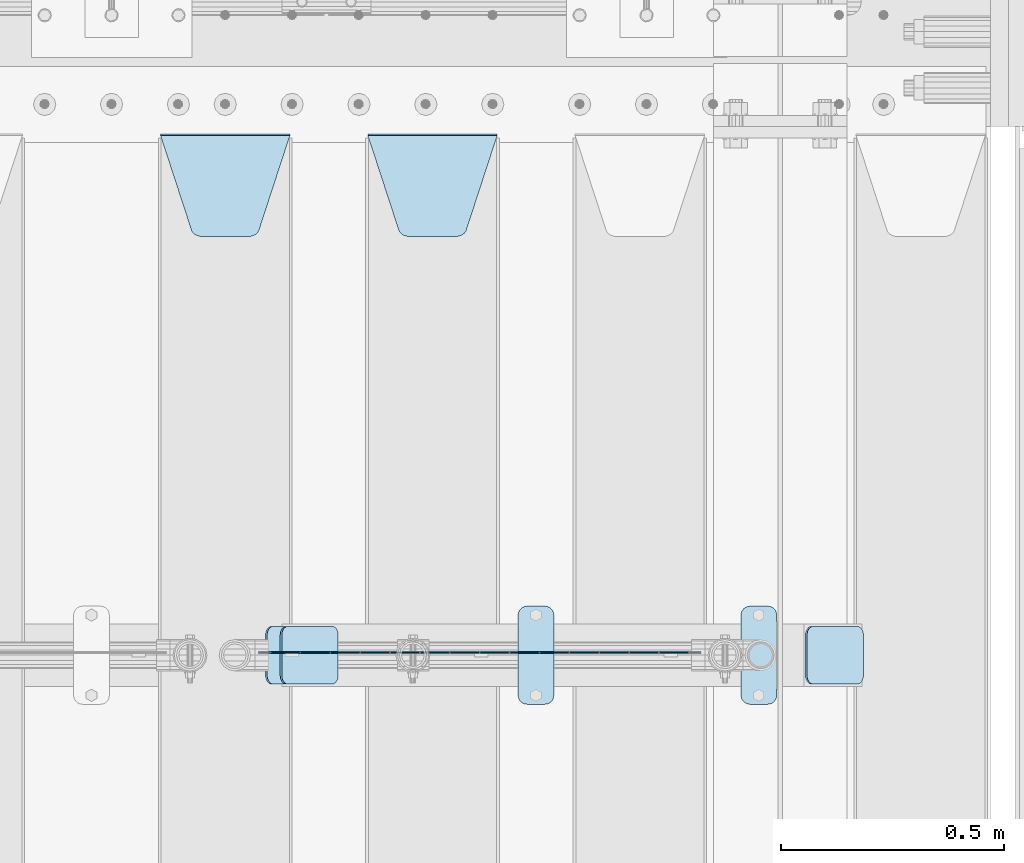
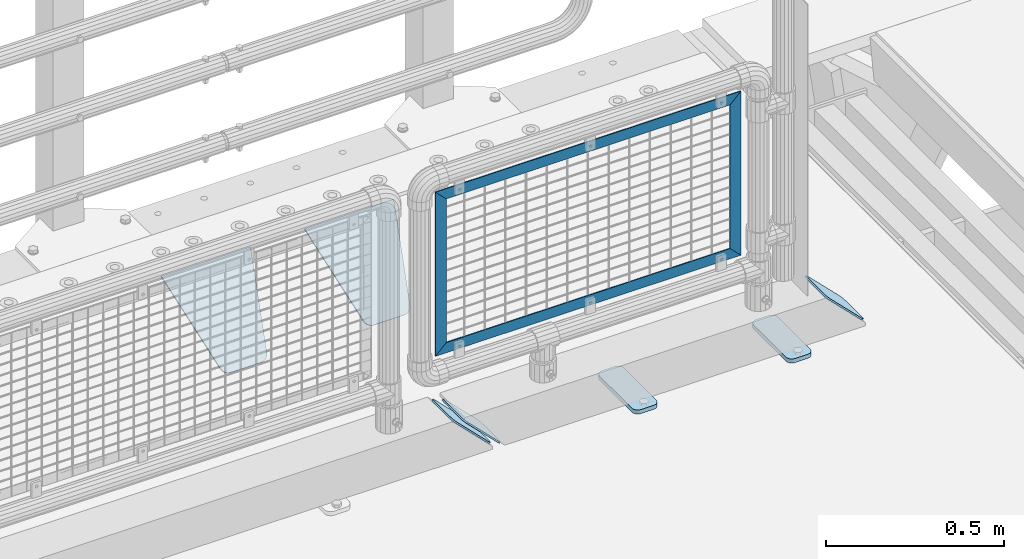
# One storey, part 230 of 247: 11 plates.
"""IFC2X3 building model written with IfcOpenShell, lengths in millimetres."""

from ifc_helpers import new_model, si_unit, frame, origin_with_axes, place, context, subcontext, project, spatial, faceted_brep, material, type_object, element, save


model = new_model("IFC2X3")

# Units and contexts
model_context = context("Model", 3, precision=1e-05, world=origin_with_axes())
body_context = subcontext(model_context, "Body", "Model", "MODEL_VIEW")
ifc_project = project(units=[si_unit("LENGTHUNIT", "METRE", prefix="MILLI"), si_unit("AREAUNIT", "SQUARE_METRE"), si_unit("VOLUMEUNIT", "CUBIC_METRE"), si_unit("MASSUNIT", "GRAM", prefix="KILO"), si_unit("TIMEUNIT", "SECOND"), si_unit("PLANEANGLEUNIT", "RADIAN"), si_unit("SOLIDANGLEUNIT", "STERADIAN"), si_unit("THERMODYNAMICTEMPERATUREUNIT", "DEGREE_CELSIUS"), si_unit("LUMINOUSINTENSITYUNIT", "LUMEN")], contexts=[model_context])

# Site, building, storey
site_placement = place(None, origin_with_axes())
site = spatial("IfcSite", under=ifc_project, at=site_placement, CompositionType="ELEMENT")
building_placement = place(site_placement, origin_with_axes())
building = spatial("IfcBuilding", under=site, at=building_placement, Name="Standard", CompositionType="ELEMENT")
storey_placement = place(building_placement, origin_with_axes())
storey = spatial("IfcBuildingStorey", under=building, at=storey_placement, Name="Undefined", CompositionType="ELEMENT", Elevation=0.0)

# Plates
ifc_material_1 = material(Name="STEEL/S355J2")
plate_type_1 = type_object("IfcPlateType", PredefinedType="NOTDEFINED")
plate_1_placement = place(storey_placement, frame((16257.0, 7774.5, 21.0199999999977), z_axis=(1.0, 0.0, 0.0), x_axis=(0.0, -0.999999999999548, -9.5100000000016e-07)))
element("IfcPlate", 1, at=plate_1_placement, inside=storey, type_object=plate_type_1, material=ifc_material_1, context=body_context, shape_type="Brep", body=[
    faceted_brep([(0.0, -7.0, 20.0), (0.0, -7.0, 60.0), (0.0, 7.0, 60.0), (0.0, 7.0, 20.0), (0.384294391935327, -7.0, 63.9018064403226), (0.384294391935327, 7.0, 63.9018064403226), (1.52240934977453, -7.0, 67.6536686473009), (1.52240934977453, 7.0, 67.6536686473009), (3.37060775394912, -7.0, 71.1114046603925), (3.37060775394912, 7.0, 71.1114046603925), (5.85786437626939, -7.0, 74.1421356237315), (5.85786437626939, 7.0, 74.1421356237315), (8.8885953396084, -7.0, 76.6293922460518), (8.8885953396084, 7.0, 76.6293922460518), (12.3463313526981, -7.0, 78.4775906502255), (12.3463313526981, 7.0, 78.4775906502255), (16.0981935596774, -7.0, 79.6157056080647), (16.0981935596774, 7.0, 79.6157056080647), (20.0, -7.0, 80.0), (20.0, 7.0, 80.0), (200.0, -7.0, 80.0), (200.0, 7.0, 80.0), (203.901806440323, -7.0, 79.6157056080647), (203.901806440323, 7.0, 79.6157056080647), (207.653668647302, -7.0, 78.4775906502255), (207.653668647302, 7.0, 78.4775906502255), (211.111404660392, -7.0, 76.6293922460518), (211.111404660392, 7.0, 76.6293922460518), (214.142135623731, -7.0, 74.1421356237315), (214.142135623731, 7.0, 74.1421356237315), (216.629392246051, -7.0, 71.1114046603925), (216.629392246051, 7.0, 71.1114046603925), (218.477590650225, -7.0, 67.6536686473009), (218.477590650225, 7.0, 67.6536686473009), (219.615705608065, -7.0, 63.9018064403226), (219.615705608065, 7.0, 63.9018064403226), (220.0, -7.0, 60.0), (220.0, 7.0, 60.0), (220.0, -7.0, 20.0), (220.0, 7.0, 20.0), (219.615705608065, -7.0, 16.0981935596774), (219.615705608065, 7.0, 16.0981935596774), (218.477590650225, -7.0, 12.3463313526991), (218.477590650225, 7.0, 12.3463313526991), (216.629392246051, -7.0, 8.88859533960749), (216.629392246051, 7.0, 8.88859533960749), (214.142135623731, -7.0, 5.85786437626848), (214.142135623731, 7.0, 5.85786437626848), (211.111404660392, -7.0, 3.37060775394821), (211.111404660392, 7.0, 3.37060775394821), (207.653668647302, -7.0, 1.52240934977453), (207.653668647302, 7.0, 1.52240934977453), (203.901806440323, -7.0, 0.384294391935327), (203.901806440323, 7.0, 0.384294391935327), (200.0, -7.0, 0.0), (200.0, 7.0, 0.0), (20.0, -7.0, 0.0), (20.0, 7.0, 0.0), (16.0981935596774, -7.0, 0.384294391935327), (16.0981935596774, 7.0, 0.384294391935327), (12.3463313526981, -7.0, 1.52240934977453), (12.3463313526981, 7.0, 1.52240934977453), (8.8885953396084, -7.0, 3.37060775394821), (8.8885953396084, 7.0, 3.37060775394821), (5.85786437626939, -7.0, 5.85786437626848), (5.85786437626939, 7.0, 5.85786437626848), (3.37060775394912, -7.0, 8.88859533960749), (3.37060775394912, 7.0, 8.88859533960749), (1.52240934977453, -7.0, 12.3463313526991), (1.52240934977453, 7.0, 12.3463313526991), (0.384294391935327, -7.0, 16.0981935596774), (0.384294391935327, 7.0, 16.0981935596774)], [[[0, 1, 2, 3]], [[1, 4, 5, 2]], [[4, 6, 7, 5]], [[6, 8, 9, 7]], [[8, 10, 11, 9]], [[10, 12, 13, 11]], [[12, 14, 15, 13]], [[14, 16, 17, 15]], [[16, 18, 19, 17]], [[18, 20, 21, 19]], [[20, 22, 23, 21]], [[22, 24, 25, 23]], [[24, 26, 27, 25]], [[26, 28, 29, 27]], [[28, 30, 31, 29]], [[30, 32, 33, 31]], [[32, 34, 35, 33]], [[34, 36, 37, 35]], [[36, 38, 39, 37]], [[38, 40, 41, 39]], [[40, 42, 43, 41]], [[42, 44, 45, 43]], [[44, 46, 47, 45]], [[46, 48, 49, 47]], [[48, 50, 51, 49]], [[50, 52, 53, 51]], [[52, 54, 55, 53]], [[54, 56, 57, 55]], [[56, 58, 59, 57]], [[58, 60, 61, 59]], [[60, 62, 63, 61]], [[62, 64, 65, 63]], [[64, 66, 67, 65]], [[66, 68, 69, 67]], [[68, 70, 71, 69]], [[70, 0, 3, 71]], [[5, 7, 9, 11, 13, 15, 17, 19, 21, 23, 25, 27, 29, 31, 33, 35, 37, 39, 41, 43, 45, 47, 49, 51, 53, 55, 57, 59, 61, 63, 65, 67, 69, 71, 3, 2]], [[70, 68, 66, 64, 62, 60, 58, 56, 54, 52, 50, 48, 46, 44, 42, 40, 38, 36, 34, 32, 30, 28, 26, 24, 22, 20, 18, 16, 14, 12, 10, 8, 6, 4, 1, 0]]]),
])
plate_2_placement = place(storey_placement, frame((15757.0, 7774.5, 21.0199999999977), z_axis=(1.0, 0.0, 0.0), x_axis=(0.0, -0.999999999999548, -9.5100000000016e-07)))
element("IfcPlate", 2, at=plate_2_placement, inside=storey, type_object=plate_type_1, material=ifc_material_1, context=body_context, shape_type="Brep", body=[
    faceted_brep([(0.0, -7.0, 20.0), (0.0, -7.0, 60.0), (0.0, 7.0, 60.0), (0.0, 7.0, 20.0), (0.384294391935327, -7.0, 63.9018064403226), (0.384294391935327, 7.0, 63.9018064403226), (1.52240934977453, -7.0, 67.6536686473009), (1.52240934977453, 7.0, 67.6536686473009), (3.37060775394912, -7.0, 71.1114046603925), (3.37060775394912, 7.0, 71.1114046603925), (5.85786437626939, -7.0, 74.1421356237315), (5.85786437626939, 7.0, 74.1421356237315), (8.8885953396084, -7.0, 76.6293922460518), (8.8885953396084, 7.0, 76.6293922460518), (12.3463313526981, -7.0, 78.4775906502255), (12.3463313526981, 7.0, 78.4775906502255), (16.0981935596774, -7.0, 79.6157056080647), (16.0981935596774, 7.0, 79.6157056080647), (20.0, -7.0, 80.0), (20.0, 7.0, 80.0), (200.0, -7.0, 80.0), (200.0, 7.0, 80.0), (203.901806440323, -7.0, 79.6157056080647), (203.901806440323, 7.0, 79.6157056080647), (207.653668647302, -7.0, 78.4775906502255), (207.653668647302, 7.0, 78.4775906502255), (211.111404660392, -7.0, 76.6293922460518), (211.111404660392, 7.0, 76.6293922460518), (214.142135623731, -7.0, 74.1421356237315), (214.142135623731, 7.0, 74.1421356237315), (216.629392246051, -7.0, 71.1114046603925), (216.629392246051, 7.0, 71.1114046603925), (218.477590650225, -7.0, 67.6536686473009), (218.477590650225, 7.0, 67.6536686473009), (219.615705608065, -7.0, 63.9018064403226), (219.615705608065, 7.0, 63.9018064403226), (220.0, -7.0, 60.0), (220.0, 7.0, 60.0), (220.0, -7.0, 20.0), (220.0, 7.0, 20.0), (219.615705608065, -7.0, 16.0981935596774), (219.615705608065, 7.0, 16.0981935596774), (218.477590650225, -7.0, 12.3463313526991), (218.477590650225, 7.0, 12.3463313526991), (216.629392246051, -7.0, 8.88859533960749), (216.629392246051, 7.0, 8.88859533960749), (214.142135623731, -7.0, 5.85786437626848), (214.142135623731, 7.0, 5.85786437626848), (211.111404660392, -7.0, 3.37060775394821), (211.111404660392, 7.0, 3.37060775394821), (207.653668647302, -7.0, 1.52240934977453), (207.653668647302, 7.0, 1.52240934977453), (203.901806440323, -7.0, 0.384294391935327), (203.901806440323, 7.0, 0.384294391935327), (200.0, -7.0, 0.0), (200.0, 7.0, 0.0), (20.0, -7.0, 0.0), (20.0, 7.0, 0.0), (16.0981935596774, -7.0, 0.384294391935327), (16.0981935596774, 7.0, 0.384294391935327), (12.3463313526981, -7.0, 1.52240934977453), (12.3463313526981, 7.0, 1.52240934977453), (8.8885953396084, -7.0, 3.37060775394821), (8.8885953396084, 7.0, 3.37060775394821), (5.85786437626939, -7.0, 5.85786437626848), (5.85786437626939, 7.0, 5.85786437626848), (3.37060775394912, -7.0, 8.88859533960749), (3.37060775394912, 7.0, 8.88859533960749), (1.52240934977453, -7.0, 12.3463313526991), (1.52240934977453, 7.0, 12.3463313526991), (0.384294391935327, -7.0, 16.0981935596774), (0.384294391935327, 7.0, 16.0981935596774)], [[[0, 1, 2, 3]], [[1, 4, 5, 2]], [[4, 6, 7, 5]], [[6, 8, 9, 7]], [[8, 10, 11, 9]], [[10, 12, 13, 11]], [[12, 14, 15, 13]], [[14, 16, 17, 15]], [[16, 18, 19, 17]], [[18, 20, 21, 19]], [[20, 22, 23, 21]], [[22, 24, 25, 23]], [[24, 26, 27, 25]], [[26, 28, 29, 27]], [[28, 30, 31, 29]], [[30, 32, 33, 31]], [[32, 34, 35, 33]], [[34, 36, 37, 35]], [[36, 38, 39, 37]], [[38, 40, 41, 39]], [[40, 42, 43, 41]], [[42, 44, 45, 43]], [[44, 46, 47, 45]], [[46, 48, 49, 47]], [[48, 50, 51, 49]], [[50, 52, 53, 51]], [[52, 54, 55, 53]], [[54, 56, 57, 55]], [[56, 58, 59, 57]], [[58, 60, 61, 59]], [[60, 62, 63, 61]], [[62, 64, 65, 63]], [[64, 66, 67, 65]], [[66, 68, 69, 67]], [[68, 70, 71, 69]], [[70, 0, 3, 71]], [[5, 7, 9, 11, 13, 15, 17, 19, 21, 23, 25, 27, 29, 31, 33, 35, 37, 39, 41, 43, 45, 47, 49, 51, 53, 55, 57, 59, 61, 63, 65, 67, 69, 71, 3, 2]], [[70, 68, 66, 64, 62, 60, 58, 56, 54, 52, 50, 48, 46, 44, 42, 40, 38, 36, 34, 32, 30, 28, 26, 24, 22, 20, 18, 16, 14, 12, 10, 8, 6, 4, 1, 0]]]),
])
ifc_material_2 = material(Name="STEEL/S355N")
plate_type_2 = type_object("IfcPlateType", PredefinedType="NOTDEFINED")
plate_3_placement = place(storey_placement, frame((15420.0, 8831.76776695594, -1.767766952965), z_axis=(0.0, -0.707106781186548, -0.707106781186547), x_axis=(1.0, 0.0, 0.0)))
element("IfcPlate", 3, at=plate_3_placement, inside=storey, type_object=plate_type_2, material=ifc_material_2, context=body_context, shape_type="Brep", body=[
    faceted_brep([(0.0, -2.49999999999909, 0.0), (69.345504679477, -2.5, 300.17173142483), (69.345504679477, 2.50000000000091, 300.171731424831), (0.0, 2.5, -9.09494701772928e-13), (70.9274061199576, -2.5, 304.897442415399), (70.9274061199576, 2.50000000000091, 304.8974424154), (73.3818627772307, -2.49999999999909, 309.234538108527), (73.3818627772307, 2.5, 309.234538108526), (76.6187032999551, -2.5, 313.023683126102), (76.6187032999551, 2.50000000000091, 313.023683126102), (80.5190132704993, -2.49999999999909, 316.125672595371), (80.5190132704993, 2.50000000000091, 316.125672595372), (84.9395038596849, -2.49999999999909, 318.426546230476), (84.9395038596849, 2.5, 318.426546230475), (89.7177759439219, -2.5, 319.841774983274), (89.7177759439219, 2.50000000000091, 319.841774983275), (94.678286292652, -2.5, 320.319366455077), (94.678286292652, 2.50000000000091, 320.319366455077), (195.321713707348, -2.5, 320.319366455077), (195.321713707348, 2.50000000000091, 320.319366455077), (200.282224056078, -2.5, 319.841774983274), (200.282224056078, 2.50000000000091, 319.841774983275), (205.060496140315, -2.5, 318.426546230475), (205.060496140315, 2.5, 318.426546230474), (209.480986729501, -2.49999999999818, 316.12567259537), (209.480986729501, 2.50000000000091, 316.12567259537), (213.381296700045, -2.5, 313.023683126101), (213.381296700045, 2.50000000000091, 313.023683126101), (216.618137222769, -2.5, 309.234538108525), (216.618137222769, 2.5, 309.234538108525), (219.072593880042, -2.49999999999909, 304.897442415398), (219.072593880042, 2.5, 304.897442415398), (220.654495320523, -2.5, 300.17173142483), (220.654495320523, 2.50000000000091, 300.171731424831), (290.0, -2.49999999999909, 0.0), (290.0, 2.5, -9.09494701772928e-13)], [[[0, 1, 2, 3]], [[1, 4, 5, 2]], [[4, 6, 7, 5]], [[6, 8, 9, 7]], [[8, 10, 11, 9]], [[10, 12, 13, 11]], [[12, 14, 15, 13]], [[14, 16, 17, 15]], [[16, 18, 19, 17]], [[18, 20, 21, 19]], [[20, 22, 23, 21]], [[22, 24, 25, 23]], [[24, 26, 27, 25]], [[26, 28, 29, 27]], [[28, 30, 31, 29]], [[30, 32, 33, 31]], [[32, 34, 35, 33]], [[34, 0, 3, 35]], [[5, 7, 9, 11, 13, 15, 17, 19, 21, 23, 25, 27, 29, 31, 33, 35, 3, 2]], [[34, 32, 30, 28, 26, 24, 22, 20, 18, 16, 14, 12, 10, 8, 6, 4, 1, 0]]]),
])
plate_4_placement = place(storey_placement, frame((14955.0, 8831.76776695594, -1.767766952965), z_axis=(0.0, -0.707106781186548, -0.707106781186547), x_axis=(1.0, 0.0, 0.0)))
element("IfcPlate", 4, at=plate_4_placement, inside=storey, type_object=plate_type_2, material=ifc_material_2, context=body_context, shape_type="Brep", body=[
    faceted_brep([(0.0, -2.49999999999909, 0.0), (69.345504679477, -2.5, 300.17173142483), (69.345504679477, 2.50000000000091, 300.171731424831), (0.0, 2.5, -9.09494701772928e-13), (70.9274061199576, -2.5, 304.897442415399), (70.9274061199576, 2.50000000000091, 304.8974424154), (73.3818627772307, -2.49999999999909, 309.234538108527), (73.3818627772307, 2.5, 309.234538108526), (76.6187032999551, -2.5, 313.023683126102), (76.6187032999551, 2.50000000000091, 313.023683126102), (80.5190132704993, -2.49999999999909, 316.125672595371), (80.5190132704993, 2.50000000000091, 316.125672595372), (84.9395038596849, -2.49999999999909, 318.426546230476), (84.9395038596849, 2.5, 318.426546230475), (89.7177759439219, -2.5, 319.841774983274), (89.7177759439219, 2.50000000000091, 319.841774983275), (94.678286292652, -2.5, 320.319366455077), (94.678286292652, 2.50000000000091, 320.319366455077), (195.321713707348, -2.5, 320.319366455077), (195.321713707348, 2.50000000000091, 320.319366455077), (200.282224056078, -2.5, 319.841774983274), (200.282224056078, 2.50000000000091, 319.841774983275), (205.060496140315, -2.5, 318.426546230475), (205.060496140315, 2.5, 318.426546230474), (209.480986729501, -2.49999999999818, 316.12567259537), (209.480986729501, 2.50000000000091, 316.12567259537), (213.381296700045, -2.5, 313.023683126101), (213.381296700045, 2.50000000000091, 313.023683126101), (216.618137222769, -2.5, 309.234538108525), (216.618137222769, 2.5, 309.234538108525), (219.072593880042, -2.49999999999909, 304.897442415398), (219.072593880042, 2.5, 304.897442415398), (220.654495320523, -2.5, 300.17173142483), (220.654495320523, 2.50000000000091, 300.171731424831), (290.0, -2.49999999999909, 0.0), (290.0, 2.5, -9.09494701772928e-13)], [[[0, 1, 2, 3]], [[1, 4, 5, 2]], [[4, 6, 7, 5]], [[6, 8, 9, 7]], [[8, 10, 11, 9]], [[10, 12, 13, 11]], [[12, 14, 15, 13]], [[14, 16, 17, 15]], [[16, 18, 19, 17]], [[18, 20, 21, 19]], [[20, 22, 23, 21]], [[22, 24, 25, 23]], [[24, 26, 27, 25]], [[26, 28, 29, 27]], [[28, 30, 31, 29]], [[30, 32, 33, 31]], [[32, 34, 35, 33]], [[34, 0, 3, 35]], [[5, 7, 9, 11, 13, 15, 17, 19, 21, 23, 25, 27, 29, 31, 33, 35, 3, 2]], [[34, 32, 30, 28, 26, 24, 22, 20, 18, 16, 14, 12, 10, 8, 6, 4, 1, 0]]]),
])
ifc_material_3 = material(Name="Misc_Undefined")
plate_type_3 = type_object("IfcPlateType", PredefinedType="NOTDEFINED")
plate_5_placement = place(storey_placement, frame((15210.1100258824, 7670.4999645044, 879.520017263597), z_axis=(-0.707106773186475, 4.52999999771556e-07, -0.707106789186475), x_axis=(-0.707106789186492, 3.85000008583224e-07, 0.707106773186498)))
element("IfcPlate", 5, at=plate_5_placement, inside=storey, type_object=plate_type_3, material=ifc_material_3, context=body_context, shape_type="Brep", body=[
    faceted_brep([(1.81898940354586e-12, -1.5, -5.6843418860808e-14), (-348.603637695373, -1.49999999999909, 348.603668212892), (-348.603637695374, 1.50000000000091, 348.603668212891), (1.81898940354586e-12, 1.5, -5.6843418860808e-14), (-348.603637695382, -1.49999999999818, 398.101165771484), (-348.603637695382, 1.50000000000091, 398.101165771483), (49.4974975585919, -1.49999999999909, 2.00088834390044e-11), (49.4974975585919, 1.50000000000091, 2.36468622460961e-11)], [[[0, 1, 2, 3]], [[1, 4, 5, 2]], [[4, 6, 7, 5]], [[6, 0, 3, 7]], [[5, 7, 3, 2]], [[6, 4, 1, 0]]]),
])
plate_6_placement = place(storey_placement, frame((15210.1100003336, 7670.49998832922, 386.520006105209), z_axis=(0.707106845186484, -4.15000000539602e-07, -0.707106717186484), x_axis=(-0.707106773186475, 4.52999999771556e-07, -0.707106789186475)))
element("IfcPlate", 6, at=plate_6_placement, inside=storey, type_object=plate_type_3, material=ifc_material_3, context=body_context, shape_type="Brep", body=[
    faceted_brep([(1.81898940354586e-12, -1.5, -5.6843418860808e-14), (-651.521057128923, -1.50000000000091, 651.521179199219), (-651.521057128924, 1.49999999999909, 651.521179199219), (1.81898940354586e-12, 1.5, -5.6843418860808e-14), (-651.521057128926, -1.50000000000182, 701.018676757813), (-651.521057128926, 1.49999999999909, 701.018676757813), (49.4974975585919, -1.49999999999909, 2.00088834390044e-11), (49.4974784851074, 1.49999999999909, -4.54747350886464e-11)], [[[0, 1, 2, 3]], [[1, 4, 5, 2]], [[4, 6, 7, 5]], [[6, 0, 3, 7]], [[5, 7, 3, 2]], [[6, 4, 1, 0]]]),
])
plate_7_placement = place(storey_placement, frame((16166.4999993967, 7670.49978377061, 914.520000514842), z_axis=(-0.707106789186492, 3.85000008583224e-07, 0.707106773186498), x_axis=(-0.707106773186475, 4.52999999771556e-07, -0.707106789186475)))
element("IfcPlate", 7, at=plate_7_placement, inside=storey, type_object=plate_type_3, material=ifc_material_3, context=body_context, shape_type="Brep", body=[
    faceted_brep([(1.81898940354586e-12, -1.5, -5.6843418860808e-14), (701.018554687525, -1.50000000000091, 701.018615722656), (701.018554687527, 1.49999999999909, 701.018615722656), (1.81898940354586e-12, 1.5, -5.6843418860808e-14), (701.018554687524, -1.50000000000091, 651.521118164063), (701.018554687525, 1.49999999999909, 651.521118164063), (49.4974975585919, -1.49999999999909, 2.00088834390044e-11), (49.4974784851074, 1.49999999999909, -4.54747350886464e-11)], [[[0, 1, 2, 3]], [[1, 4, 5, 2]], [[4, 6, 7, 5]], [[6, 0, 3, 7]], [[5, 7, 3, 2]], [[6, 4, 1, 0]]]),
])
plate_8_placement = place(storey_placement, frame((16166.4999999862, 7670.49977880131, 914.461469028505), z_axis=(0.706514791587333, 1.29999998458982e-08, -0.707698275586642), x_axis=(-0.707698275586643, 0.0, -0.706514791587332)))
element("IfcPlate", 8, at=plate_8_placement, inside=storey, type_object=plate_type_3, material=ifc_material_3, context=body_context, shape_type="Brep", body=[
    faceted_brep([(1.81898940354586e-12, -1.5, -5.6843418860808e-14), (397.726470947266, -1.50000000000091, 398.392700195314), (397.726470947266, 1.49999999999909, 398.392700195314), (1.81898940354586e-12, 1.5, -5.6843418860808e-14), (397.767883300781, -1.50000000000091, 348.895263671877), (397.767883300781, 1.49999999999909, 348.895263671877), (49.4561042785645, -1.5, -4.91127138957381e-11), (49.4561042785626, 1.5, -4.72937244921923e-11)], [[[0, 1, 2, 3]], [[1, 4, 5, 2]], [[4, 6, 7, 5]], [[6, 0, 3, 7]], [[5, 7, 3, 2]], [[6, 4, 1, 0]]]),
])
plate_type_4 = type_object("IfcPlateType", PredefinedType="NOTDEFINED")
plate_9_placement = place(storey_placement, frame((15192.192418479, 7729.5, 166.254400376569), z_axis=(0.707410512925778, 0.0, -0.706802918925841), x_axis=(0.0, -0.999999999999548, -9.5100000000016e-07)))
element("IfcPlate", 9, at=plate_9_placement, inside=storey, type_object=plate_type_4, material=ifc_material_1, context=body_context, shape_type="Brep", body=[
    faceted_brep([(0.0, -2.50000000000182, 20.0), (0.0, -2.50000000000182, 158.926651000977), (0.0, 2.49999999999818, 158.926651000977), (0.0, 2.49999999999818, 20.0), (0.384294391935327, -2.50000000000182, 162.828457441299), (0.384294391935327, 2.49999999999818, 162.828457441299), (1.52240934977453, -2.5, 166.580319648279), (1.52240934977453, 2.49999999999818, 166.580319648279), (3.37060775394912, -2.5, 170.038055661367), (3.37060775394912, 2.49999999999818, 170.038055661367), (5.85786437626939, -2.5, 173.068786624706), (5.85786437626939, 2.49999999999818, 173.068786624706), (8.8885953396084, -2.50000000000182, 175.556043247028), (8.8885953396084, 2.49999999999818, 175.556043247027), (12.3463313526981, -2.5, 177.404241651202), (12.3463313526981, 2.49999999999818, 177.404241651202), (16.0981935596774, -2.50000000000182, 178.542356609041), (16.0981935596774, 2.49999999999818, 178.542356609041), (20.0, -2.50000000000182, 178.926651000977), (20.0, 2.49999999999818, 178.926651000975), (110.0, -2.50000000000182, 178.926651000977), (110.0, 2.49999999999818, 178.926651000975), (113.901806440323, -2.50000000000182, 178.542356609041), (113.901806440323, 2.49999999999818, 178.542356609041), (117.653668647302, -2.5, 177.404241651202), (117.653668647302, 2.49999999999818, 177.404241651202), (121.111404660392, -2.50000000000182, 175.556043247028), (121.111404660392, 2.49999999999818, 175.556043247027), (124.142135623731, -2.5, 173.068786624706), (124.142135623731, 2.49999999999818, 173.068786624706), (126.629392246051, -2.5, 170.038055661367), (126.629392246051, 2.49999999999818, 170.038055661367), (128.477590650225, -2.5, 166.580319648279), (128.477590650225, 2.49999999999818, 166.580319648279), (129.615705608065, -2.50000000000182, 162.828457441299), (129.615705608065, 2.49999999999818, 162.828457441299), (130.0, -2.50000000000182, 158.926651000977), (130.0, 2.49999999999818, 158.926651000977), (130.0, -2.50000000000182, 20.0), (130.0, 2.49999999999818, 20.0), (129.615705608065, -2.50000000000182, 16.0981935596774), (129.615705608065, 2.5, 16.0981935596774), (128.477590650225, -2.50000000000182, 12.3463313526972), (128.477590650225, 2.49999999999818, 12.3463313526991), (126.629392246051, -2.50000000000182, 8.88859533960749), (126.629392246051, 2.5, 8.88859533960749), (124.142135623731, -2.50000000000364, 5.85786437626848), (124.142135623731, 2.5, 5.85786437626848), (121.111404660392, -2.50000000000182, 3.37060775394821), (121.111404660392, 2.49999999999818, 3.37060775395003), (117.653668647302, -2.50000000000182, 1.52240934977453), (117.653668647302, 2.49999999999818, 1.52240934977272), (113.901806440323, -2.50000000000182, 0.384294391935327), (113.901806440323, 2.49999999999818, 0.384294391935327), (110.0, -2.50000000000182, -1.81898940354586e-12), (110.0, 2.49999999999818, 0.0), (20.0, -2.50000000000182, -1.81898940354586e-12), (20.0, 2.49999999999818, 0.0), (16.0981935596774, -2.50000000000182, 0.384294391935327), (16.0981935596774, 2.49999999999818, 0.384294391935327), (12.3463313526981, -2.50000000000182, 1.52240934977453), (12.3463313526981, 2.49999999999818, 1.52240934977272), (8.8885953396084, -2.50000000000182, 3.37060775394821), (8.8885953396084, 2.49999999999818, 3.37060775395003), (5.85786437626939, -2.50000000000364, 5.85786437626848), (5.85786437626939, 2.5, 5.85786437626848), (3.37060775394912, -2.50000000000182, 8.88859533960749), (3.37060775394912, 2.5, 8.88859533960749), (1.52240934977453, -2.50000000000182, 12.3463313526972), (1.52240934977453, 2.49999999999818, 12.3463313526991), (0.384294391935327, -2.50000000000182, 16.0981935596774), (0.384294391935327, 2.5, 16.0981935596774)], [[[0, 1, 2, 3]], [[1, 4, 5, 2]], [[4, 6, 7, 5]], [[6, 8, 9, 7]], [[8, 10, 11, 9]], [[10, 12, 13, 11]], [[12, 14, 15, 13]], [[14, 16, 17, 15]], [[16, 18, 19, 17]], [[18, 20, 21, 19]], [[20, 22, 23, 21]], [[22, 24, 25, 23]], [[24, 26, 27, 25]], [[26, 28, 29, 27]], [[28, 30, 31, 29]], [[30, 32, 33, 31]], [[32, 34, 35, 33]], [[34, 36, 37, 35]], [[36, 38, 39, 37]], [[38, 40, 41, 39]], [[40, 42, 43, 41]], [[42, 44, 45, 43]], [[44, 46, 47, 45]], [[46, 48, 49, 47]], [[48, 50, 51, 49]], [[50, 52, 53, 51]], [[52, 54, 55, 53]], [[54, 56, 57, 55]], [[56, 58, 59, 57]], [[58, 60, 61, 59]], [[60, 62, 63, 61]], [[62, 64, 65, 63]], [[64, 66, 67, 65]], [[66, 68, 69, 67]], [[68, 70, 71, 69]], [[70, 0, 3, 71]], [[5, 7, 9, 11, 13, 15, 17, 19, 21, 23, 25, 27, 29, 31, 33, 35, 37, 39, 41, 43, 45, 47, 49, 51, 53, 55, 57, 59, 61, 63, 65, 67, 69, 71, 3, 2]], [[70, 68, 66, 64, 62, 60, 58, 56, 54, 52, 50, 48, 46, 44, 42, 40, 38, 36, 34, 32, 30, 28, 26, 24, 22, 20, 18, 16, 14, 12, 10, 8, 6, 4, 1, 0]]]),
])
plate_10_placement = place(storey_placement, frame((16403.192418479, 7729.5, 166.254400376567), z_axis=(0.707410512925778, 0.0, -0.706802918925841), x_axis=(0.0, -0.999999999999548, -9.5100000000016e-07)))
element("IfcPlate", 10, at=plate_10_placement, inside=storey, type_object=plate_type_4, material=ifc_material_1, context=body_context, shape_type="Brep", body=[
    faceted_brep([(0.0, -2.50000000000182, 20.0), (0.0, -2.50000000000182, 158.926651000977), (0.0, 2.49999999999818, 158.926651000977), (0.0, 2.49999999999818, 20.0), (0.384294391935327, -2.50000000000182, 162.828457441299), (0.384294391935327, 2.49999999999818, 162.828457441299), (1.52240934977453, -2.5, 166.580319648279), (1.52240934977453, 2.49999999999818, 166.580319648279), (3.37060775394912, -2.5, 170.038055661367), (3.37060775394912, 2.49999999999818, 170.038055661367), (5.85786437626939, -2.5, 173.068786624706), (5.85786437626939, 2.49999999999818, 173.068786624706), (8.8885953396084, -2.50000000000182, 175.556043247028), (8.8885953396084, 2.49999999999818, 175.556043247027), (12.3463313526981, -2.5, 177.404241651202), (12.3463313526981, 2.49999999999818, 177.404241651202), (16.0981935596774, -2.50000000000182, 178.542356609041), (16.0981935596774, 2.49999999999818, 178.542356609041), (20.0, -2.50000000000182, 178.926651000977), (20.0, 2.49999999999818, 178.926651000975), (110.0, -2.50000000000182, 178.926651000977), (110.0, 2.49999999999818, 178.926651000975), (113.901806440323, -2.50000000000182, 178.542356609041), (113.901806440323, 2.49999999999818, 178.542356609041), (117.653668647302, -2.5, 177.404241651202), (117.653668647302, 2.49999999999818, 177.404241651202), (121.111404660392, -2.50000000000182, 175.556043247028), (121.111404660392, 2.49999999999818, 175.556043247027), (124.142135623731, -2.5, 173.068786624706), (124.142135623731, 2.49999999999818, 173.068786624706), (126.629392246051, -2.5, 170.038055661367), (126.629392246051, 2.49999999999818, 170.038055661367), (128.477590650225, -2.5, 166.580319648279), (128.477590650225, 2.49999999999818, 166.580319648279), (129.615705608065, -2.50000000000182, 162.828457441299), (129.615705608065, 2.49999999999818, 162.828457441299), (130.0, -2.50000000000182, 158.926651000977), (130.0, 2.49999999999818, 158.926651000977), (130.0, -2.50000000000182, 20.0), (130.0, 2.49999999999818, 20.0), (129.615705608065, -2.50000000000182, 16.0981935596774), (129.615705608065, 2.5, 16.0981935596774), (128.477590650225, -2.50000000000182, 12.3463313526972), (128.477590650225, 2.49999999999818, 12.3463313526991), (126.629392246051, -2.50000000000182, 8.88859533960749), (126.629392246051, 2.5, 8.88859533960749), (124.142135623731, -2.50000000000364, 5.85786437626848), (124.142135623731, 2.5, 5.85786437626848), (121.111404660392, -2.50000000000182, 3.37060775394821), (121.111404660392, 2.49999999999818, 3.37060775395003), (117.653668647302, -2.50000000000182, 1.52240934977453), (117.653668647302, 2.49999999999818, 1.52240934977272), (113.901806440323, -2.50000000000182, 0.384294391935327), (113.901806440323, 2.49999999999818, 0.384294391935327), (110.0, -2.50000000000182, -1.81898940354586e-12), (110.0, 2.49999999999818, 0.0), (20.0, -2.50000000000182, -1.81898940354586e-12), (20.0, 2.49999999999818, 0.0), (16.0981935596774, -2.50000000000182, 0.384294391935327), (16.0981935596774, 2.49999999999818, 0.384294391935327), (12.3463313526981, -2.50000000000182, 1.52240934977453), (12.3463313526981, 2.49999999999818, 1.52240934977272), (8.8885953396084, -2.50000000000182, 3.37060775394821), (8.8885953396084, 2.49999999999818, 3.37060775395003), (5.85786437626939, -2.50000000000364, 5.85786437626848), (5.85786437626939, 2.5, 5.85786437626848), (3.37060775394912, -2.50000000000182, 8.88859533960749), (3.37060775394912, 2.5, 8.88859533960749), (1.52240934977453, -2.50000000000182, 12.3463313526972), (1.52240934977453, 2.49999999999818, 12.3463313526991), (0.384294391935327, -2.50000000000182, 16.0981935596774), (0.384294391935327, 2.5, 16.0981935596774)], [[[0, 1, 2, 3]], [[1, 4, 5, 2]], [[4, 6, 7, 5]], [[6, 8, 9, 7]], [[8, 10, 11, 9]], [[10, 12, 13, 11]], [[12, 14, 15, 13]], [[14, 16, 17, 15]], [[16, 18, 19, 17]], [[18, 20, 21, 19]], [[20, 22, 23, 21]], [[22, 24, 25, 23]], [[24, 26, 27, 25]], [[26, 28, 29, 27]], [[28, 30, 31, 29]], [[30, 32, 33, 31]], [[32, 34, 35, 33]], [[34, 36, 37, 35]], [[36, 38, 39, 37]], [[38, 40, 41, 39]], [[40, 42, 43, 41]], [[42, 44, 45, 43]], [[44, 46, 47, 45]], [[46, 48, 49, 47]], [[48, 50, 51, 49]], [[50, 52, 53, 51]], [[52, 54, 55, 53]], [[54, 56, 57, 55]], [[56, 58, 59, 57]], [[58, 60, 61, 59]], [[60, 62, 63, 61]], [[62, 64, 65, 63]], [[64, 66, 67, 65]], [[66, 68, 69, 67]], [[68, 70, 71, 69]], [[70, 0, 3, 71]], [[5, 7, 9, 11, 13, 15, 17, 19, 21, 23, 25, 27, 29, 31, 33, 35, 37, 39, 41, 43, 45, 47, 49, 51, 53, 55, 57, 59, 61, 63, 65, 67, 69, 71, 3, 2]], [[70, 68, 66, 64, 62, 60, 58, 56, 54, 52, 50, 48, 46, 44, 42, 40, 38, 36, 34, 32, 30, 28, 26, 24, 22, 20, 18, 16, 14, 12, 10, 8, 6, 4, 1, 0]]]),
])
plate_11_placement = place(storey_placement, frame((15225.1214625381, 7729.5, 156.2514737179), z_axis=(0.707410512925778, 0.0, -0.706802918925841), x_axis=(0.0, -0.999999999999548, -9.5100000000016e-07)))
element("IfcPlate", 11, at=plate_11_placement, inside=storey, type_object=plate_type_4, material=ifc_material_1, context=body_context, shape_type="Brep", body=[
    faceted_brep([(0.0, -2.50000000000182, 20.0), (0.0, -2.50000000000182, 158.926651000977), (0.0, 2.49999999999818, 158.926651000977), (0.0, 2.49999999999818, 20.0), (0.384294391935327, -2.50000000000182, 162.828457441299), (0.384294391935327, 2.49999999999818, 162.828457441299), (1.52240934977453, -2.5, 166.580319648279), (1.52240934977453, 2.49999999999818, 166.580319648279), (3.37060775394912, -2.5, 170.038055661367), (3.37060775394912, 2.49999999999818, 170.038055661367), (5.85786437626939, -2.5, 173.068786624706), (5.85786437626939, 2.49999999999818, 173.068786624706), (8.8885953396084, -2.50000000000182, 175.556043247028), (8.8885953396084, 2.49999999999818, 175.556043247027), (12.3463313526981, -2.5, 177.404241651202), (12.3463313526981, 2.49999999999818, 177.404241651202), (16.0981935596774, -2.50000000000182, 178.542356609041), (16.0981935596774, 2.49999999999818, 178.542356609041), (20.0, -2.50000000000182, 178.926651000977), (20.0, 2.49999999999818, 178.926651000975), (110.0, -2.50000000000182, 178.926651000977), (110.0, 2.49999999999818, 178.926651000975), (113.901806440323, -2.50000000000182, 178.542356609041), (113.901806440323, 2.49999999999818, 178.542356609041), (117.653668647302, -2.5, 177.404241651202), (117.653668647302, 2.49999999999818, 177.404241651202), (121.111404660392, -2.50000000000182, 175.556043247028), (121.111404660392, 2.49999999999818, 175.556043247027), (124.142135623731, -2.5, 173.068786624706), (124.142135623731, 2.49999999999818, 173.068786624706), (126.629392246051, -2.5, 170.038055661367), (126.629392246051, 2.49999999999818, 170.038055661367), (128.477590650225, -2.5, 166.580319648279), (128.477590650225, 2.49999999999818, 166.580319648279), (129.615705608065, -2.50000000000182, 162.828457441299), (129.615705608065, 2.49999999999818, 162.828457441299), (130.0, -2.50000000000182, 158.926651000977), (130.0, 2.49999999999818, 158.926651000977), (130.0, -2.50000000000182, 20.0), (130.0, 2.49999999999818, 20.0), (129.615705608065, -2.50000000000182, 16.0981935596774), (129.615705608065, 2.5, 16.0981935596774), (128.477590650225, -2.50000000000182, 12.3463313526972), (128.477590650225, 2.49999999999818, 12.3463313526991), (126.629392246051, -2.50000000000182, 8.88859533960749), (126.629392246051, 2.5, 8.88859533960749), (124.142135623731, -2.50000000000364, 5.85786437626848), (124.142135623731, 2.5, 5.85786437626848), (121.111404660392, -2.50000000000182, 3.37060775394821), (121.111404660392, 2.49999999999818, 3.37060775395003), (117.653668647302, -2.50000000000182, 1.52240934977453), (117.653668647302, 2.49999999999818, 1.52240934977272), (113.901806440323, -2.50000000000182, 0.384294391935327), (113.901806440323, 2.49999999999818, 0.384294391935327), (110.0, -2.50000000000182, -1.81898940354586e-12), (110.0, 2.49999999999818, 0.0), (20.0, -2.50000000000182, -1.81898940354586e-12), (20.0, 2.49999999999818, 0.0), (16.0981935596774, -2.50000000000182, 0.384294391935327), (16.0981935596774, 2.49999999999818, 0.384294391935327), (12.3463313526981, -2.50000000000182, 1.52240934977453), (12.3463313526981, 2.49999999999818, 1.52240934977272), (8.8885953396084, -2.50000000000182, 3.37060775394821), (8.8885953396084, 2.49999999999818, 3.37060775395003), (5.85786437626939, -2.50000000000364, 5.85786437626848), (5.85786437626939, 2.5, 5.85786437626848), (3.37060775394912, -2.50000000000182, 8.88859533960749), (3.37060775394912, 2.5, 8.88859533960749), (1.52240934977453, -2.50000000000182, 12.3463313526972), (1.52240934977453, 2.49999999999818, 12.3463313526991), (0.384294391935327, -2.50000000000182, 16.0981935596774), (0.384294391935327, 2.5, 16.0981935596774)], [[[0, 1, 2, 3]], [[1, 4, 5, 2]], [[4, 6, 7, 5]], [[6, 8, 9, 7]], [[8, 10, 11, 9]], [[10, 12, 13, 11]], [[12, 14, 15, 13]], [[14, 16, 17, 15]], [[16, 18, 19, 17]], [[18, 20, 21, 19]], [[20, 22, 23, 21]], [[22, 24, 25, 23]], [[24, 26, 27, 25]], [[26, 28, 29, 27]], [[28, 30, 31, 29]], [[30, 32, 33, 31]], [[32, 34, 35, 33]], [[34, 36, 37, 35]], [[36, 38, 39, 37]], [[38, 40, 41, 39]], [[40, 42, 43, 41]], [[42, 44, 45, 43]], [[44, 46, 47, 45]], [[46, 48, 49, 47]], [[48, 50, 51, 49]], [[50, 52, 53, 51]], [[52, 54, 55, 53]], [[54, 56, 57, 55]], [[56, 58, 59, 57]], [[58, 60, 61, 59]], [[60, 62, 63, 61]], [[62, 64, 65, 63]], [[64, 66, 67, 65]], [[66, 68, 69, 67]], [[68, 70, 71, 69]], [[70, 0, 3, 71]], [[5, 7, 9, 11, 13, 15, 17, 19, 21, 23, 25, 27, 29, 31, 33, 35, 37, 39, 41, 43, 45, 47, 49, 51, 53, 55, 57, 59, 61, 63, 65, 67, 69, 71, 3, 2]], [[70, 68, 66, 64, 62, 60, 58, 56, 54, 52, 50, 48, 46, 44, 42, 40, 38, 36, 34, 32, 30, 28, 26, 24, 22, 20, 18, 16, 14, 12, 10, 8, 6, 4, 1, 0]]]),
])

save(model, "model.ifc")
